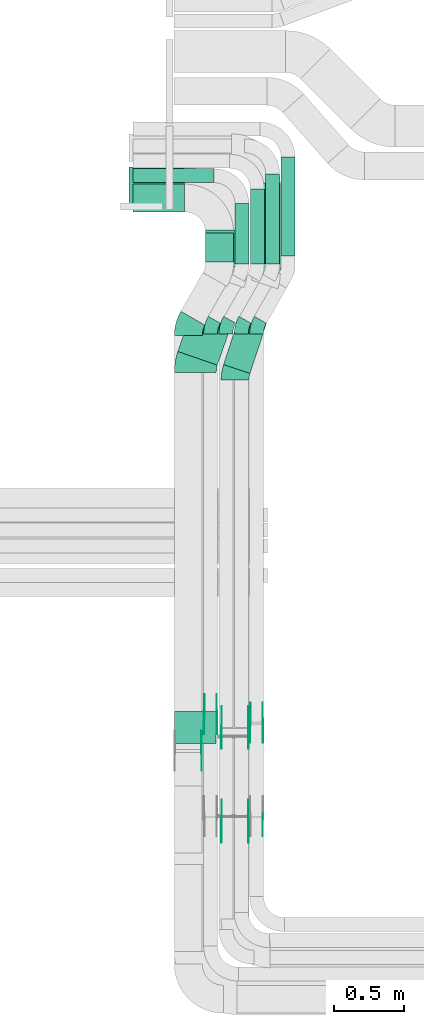
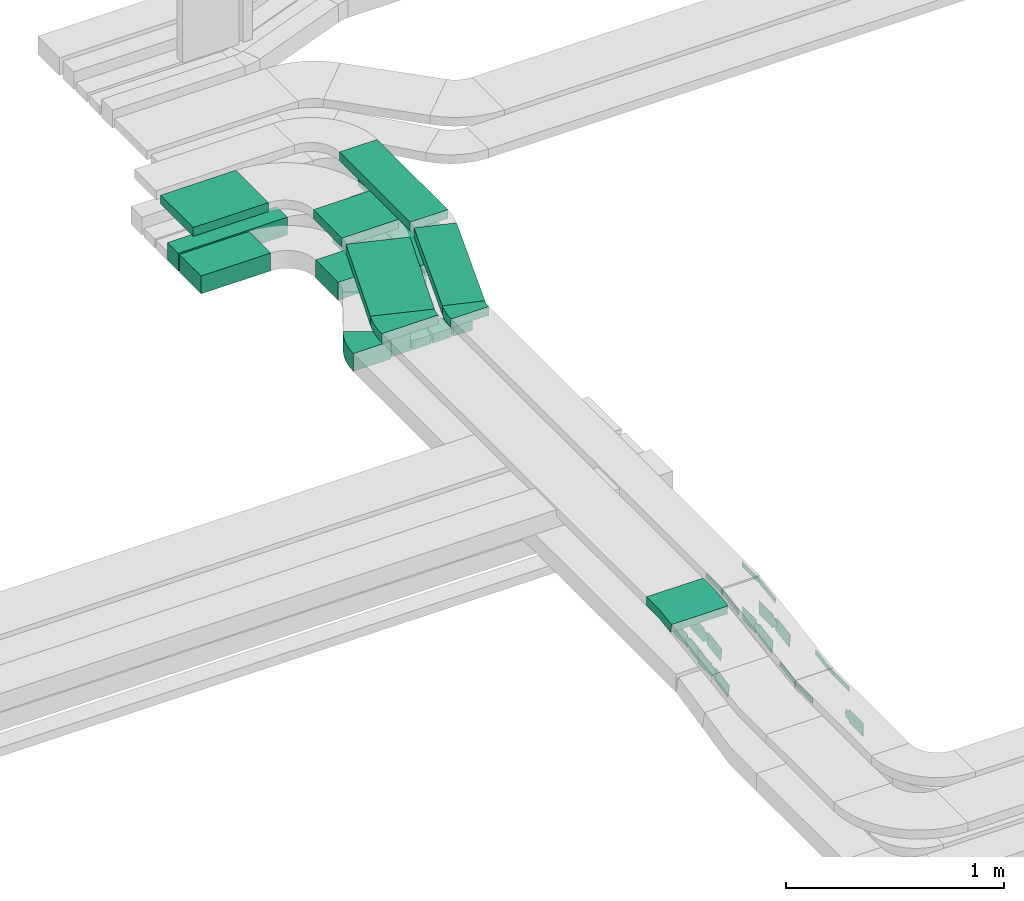
# One storey, part 5 of 28: 27 flow fittings, 12 flow segments.
"""IFC2X3 building model written with IfcOpenShell, lengths in millimetres."""

from ifc_helpers import new_model, entity, si_unit, converted_unit, derived_unit, direction, frame, frame_2d, origin, origin_2d_with_axis, place, context, subcontext, project, spatial, polyline, circle_curve, parameter, trimmed, segment, composite_curve, rectangle, outline, extrude, source, transform, mapped, material, type_object, type_shapes, element, save


model = new_model("IFC2X3")

# Units and contexts
model_context = context("Model", 3, precision=0.01, world=origin(), true_north=direction((6.12303176911189e-17, 1.0)))
body_context = subcontext(model_context, "Body", "Model", "MODEL_VIEW")
ifc_project = project(units=[si_unit("LENGTHUNIT", "METRE", prefix="MILLI"), si_unit("AREAUNIT", "SQUARE_METRE"), si_unit("VOLUMEUNIT", "CUBIC_METRE"), converted_unit("PLANEANGLEUNIT", "DEGREE", entity("IfcRatioMeasure", 0.0174532925199433), si_unit("PLANEANGLEUNIT", "RADIAN"), dimensions=[0, 0, 0, 0, 0, 0, 0]), si_unit("MASSUNIT", "GRAM", prefix="KILO"), derived_unit("MASSDENSITYUNIT", [(si_unit("MASSUNIT", "GRAM", prefix="KILO"), 1), (si_unit("LENGTHUNIT", "METRE"), -3)]), derived_unit("MOMENTOFINERTIAUNIT", [(si_unit("LENGTHUNIT", "METRE"), 4)]), si_unit("TIMEUNIT", "SECOND"), si_unit("FREQUENCYUNIT", "HERTZ"), si_unit("THERMODYNAMICTEMPERATUREUNIT", "DEGREE_CELSIUS"), derived_unit("THERMALTRANSMITTANCEUNIT", [(si_unit("MASSUNIT", "GRAM", prefix="KILO"), 1), (si_unit("THERMODYNAMICTEMPERATUREUNIT", "KELVIN"), -1), (si_unit("TIMEUNIT", "SECOND"), -3)]), derived_unit("VOLUMETRICFLOWRATEUNIT", [(si_unit("LENGTHUNIT", "METRE"), 3), (si_unit("TIMEUNIT", "SECOND"), -1)]), derived_unit("MASSFLOWRATEUNIT", [(si_unit("MASSUNIT", "GRAM", prefix="KILO"), 1), (si_unit("TIMEUNIT", "SECOND"), -1)]), derived_unit("ROTATIONALFREQUENCYUNIT", [(si_unit("TIMEUNIT", "SECOND"), -1)]), si_unit("ELECTRICCURRENTUNIT", "AMPERE"), si_unit("ELECTRICVOLTAGEUNIT", "VOLT"), si_unit("POWERUNIT", "WATT"), si_unit("FORCEUNIT", "NEWTON", prefix="KILO"), si_unit("ILLUMINANCEUNIT", "LUX"), si_unit("LUMINOUSFLUXUNIT", "LUMEN"), si_unit("LUMINOUSINTENSITYUNIT", "CANDELA"), derived_unit("USERDEFINED", [(si_unit("MASSUNIT", "GRAM", prefix="KILO"), -1), (si_unit("LENGTHUNIT", "METRE"), -2), (si_unit("TIMEUNIT", "SECOND"), 3), (si_unit("LUMINOUSFLUXUNIT", "LUMEN"), 1)]), derived_unit("LINEARVELOCITYUNIT", [(si_unit("LENGTHUNIT", "METRE"), 1), (si_unit("TIMEUNIT", "SECOND"), -1)]), si_unit("PRESSUREUNIT", "PASCAL"), derived_unit("USERDEFINED", [(si_unit("LENGTHUNIT", "METRE"), -2), (si_unit("MASSUNIT", "GRAM", prefix="KILO"), 1), (si_unit("TIMEUNIT", "SECOND"), -2)]), derived_unit("LINEARFORCEUNIT", [(si_unit("MASSUNIT", "GRAM", prefix="KILO"), 1), (si_unit("LENGTHUNIT", "METRE"), 1), (si_unit("TIMEUNIT", "SECOND"), -2), (si_unit("LENGTHUNIT", "METRE"), -1)]), derived_unit("PLANARFORCEUNIT", [(si_unit("MASSUNIT", "GRAM", prefix="KILO"), 1), (si_unit("LENGTHUNIT", "METRE"), 1), (si_unit("TIMEUNIT", "SECOND"), -2), (si_unit("LENGTHUNIT", "METRE"), -2)])], contexts=[model_context])

# Site, building, storey
site_placement = place(None, origin())
site = spatial("IfcSite", under=ifc_project, at=site_placement, CompositionType="ELEMENT")
building_placement = place(site_placement, origin())
building = spatial("IfcBuilding", under=site, at=building_placement, CompositionType="ELEMENT")
storey_placement = place(building_placement, frame((0.0, 0.0, 15900.0)))
storey = spatial("IfcBuildingStorey", under=building, at=storey_placement, CompositionType="ELEMENT", Elevation=15900.0)

# Flow segments
cable_carrier_segment_type = type_object("IfcCableCarrierSegmentType", PredefinedType="CABLETRAYSEGMENT")
flow_segment_1_placement = place(storey_placement, frame((17298.54, 13653.75, 2607.26)))
element("IfcFlowSegment", 1, at=flow_segment_1_placement, inside=storey, type_object=cable_carrier_segment_type, context=body_context, shape_type="SweptSolid", body=[
    extrude(rectangle(XDim=709.169713057409, YDim=99.9999999999989, at=origin_2d_with_axis()), frame((50.0, 354.58, 0.0), z_axis=(0.0, 0.0, 1.0), x_axis=(0.0, 1.0, 0.0)), (0.0, 0.0, 1.0), 99.9999999999989),
])
flow_segment_2_placement = place(storey_placement, frame((16968.54, 13598.0, 2607.26)))
element("IfcFlowSegment", 2, at=flow_segment_2_placement, inside=storey, type_object=cable_carrier_segment_type, context=body_context, shape_type="SweptSolid", body=[
    extrude(rectangle(XDim=431.001407067845, YDim=99.9999999999989, at=origin_2d_with_axis()), frame((50.0, 215.5, 0.0), z_axis=(0.0, 0.0, 1.0), x_axis=(0.0, 1.0, 0.0)), (0.0, 0.0, 1.0), 99.9999999999989),
])
flow_segment_3_placement = place(storey_placement, frame((17078.54, 13598.0, 2607.26)))
element("IfcFlowSegment", 3, at=flow_segment_3_placement, inside=storey, type_object=cable_carrier_segment_type, context=body_context, shape_type="SweptSolid", body=[
    extrude(rectangle(XDim=534.919754710368, YDim=99.9999999999989, at=origin_2d_with_axis()), frame((50.0, 267.46, 0.0), z_axis=(0.0, 0.0, 1.0), x_axis=(0.0, 1.0, 0.0)), (0.0, 0.0, 1.0), 50.0000000000016),
])
flow_segment_4_placement = place(storey_placement, frame((16758.54, 13611.27, 2607.26)))
element("IfcFlowSegment", 4, at=flow_segment_4_placement, inside=storey, type_object=cable_carrier_segment_type, context=body_context, shape_type="SweptSolid", body=[
    extrude(rectangle(XDim=207.731345745393, YDim=200.000000000002, at=origin_2d_with_axis()), frame((100.0, 103.87, 0.0), z_axis=(0.0, 0.0, 1.0), x_axis=(0.0, 1.0, 0.0)), (0.0, 0.0, 1.0), 99.9999999999989),
])
flow_segment_5_placement = place(storey_placement, frame((17093.54, 13530.09, 2927.26)))
element("IfcFlowSegment", 5, at=flow_segment_5_placement, inside=storey, type_object=cable_carrier_segment_type, context=body_context, shape_type="SweptSolid", body=[
    extrude(rectangle(XDim=649.073739865579, YDim=200.000000000002, at=origin_2d_with_axis()), frame((100.0, 324.54, 0.0), z_axis=(0.0, 0.0, 1.0), x_axis=(0.0, 1.0, 0.0)), (0.0, 0.0, 1.0), 50.0000000000016),
])
flow_segment_6_placement = place(storey_placement, frame((16758.54, 13575.33, 2927.26)))
element("IfcFlowSegment", 6, at=flow_segment_6_placement, inside=storey, type_object=cable_carrier_segment_type, context=body_context, shape_type="SweptSolid", body=[
    extrude(rectangle(XDim=264.198022174949, YDim=300.000000000001, at=origin_2d_with_axis()), frame((150.0, 132.1, 0.0), z_axis=(0.0, 0.0, 1.0), x_axis=(0.0, 1.0, 0.0)), (0.0, 0.0, 1.0), 50.0000000000016),
])
flow_segment_7_placement = place(storey_placement, frame((17188.54, 13598.0, 2607.26)))
element("IfcFlowSegment", 7, at=flow_segment_7_placement, inside=storey, type_object=cable_carrier_segment_type, context=body_context, shape_type="SweptSolid", body=[
    extrude(rectangle(XDim=644.919754710367, YDim=99.9999999999989, at=origin_2d_with_axis()), frame((50.0, 322.46, 0.0), z_axis=(0.0, 0.0, 1.0), x_axis=(0.0, 1.0, 0.0)), (0.0, 0.0, 1.0), 50.0000000000016),
])
flow_segment_8_placement = place(storey_placement, frame((16238.54, 13970.0, 2607.26)))
element("IfcFlowSegment", 8, at=flow_segment_8_placement, inside=storey, type_object=cable_carrier_segment_type, context=body_context, shape_type="SweptSolid", body=[
    extrude(rectangle(XDim=369.000000000007, YDim=200.000000000002, at=origin_2d_with_axis()), frame((184.5, 100.0, 0.0), z_axis=(0.0, 0.0, 1.0), x_axis=(-1.0, 0.0, 0.0)), (0.0, 0.0, 1.0), 99.9999999999989),
])
flow_segment_9_placement = place(storey_placement, frame((16238.54, 14180.0, 2607.26)))
element("IfcFlowSegment", 9, at=flow_segment_9_placement, inside=storey, type_object=cable_carrier_segment_type, context=body_context, shape_type="SweptSolid", body=[
    extrude(rectangle(XDim=579.000000000005, YDim=99.9999999999989, at=origin_2d_with_axis()), frame((289.5, 50.0, 0.0), z_axis=(0.0, 0.0, 1.0), x_axis=(-1.0, 0.0, 0.0)), (0.0, 0.0, 1.0), 99.9999999999989),
])
flow_segment_10_placement = place(storey_placement, frame((16558.44, 12871.39, 2927.26)))
element("IfcFlowSegment", 10, at=flow_segment_10_placement, inside=storey, type_object=cable_carrier_segment_type, context=body_context, shape_type="SweptSolid", body=[
    extrude(rectangle(XDim=587.335852841362, YDim=299.999999999998, at=origin_2d_with_axis()), frame((237.58, 326.53, 0.0), z_axis=(0.0, 0.0, 1.0), x_axis=(-0.326179561314503, -0.945307830169981, 0.0)), (0.0, 0.0, 1.0), 50.0000000000016),
])
flow_segment_11_placement = place(storey_placement, frame((16886.34, 12812.75, 2927.26)))
element("IfcFlowSegment", 11, at=flow_segment_11_placement, inside=storey, type_object=cable_carrier_segment_type, context=body_context, shape_type="SweptSolid", body=[
    extrude(rectangle(XDim=637.96363640816, YDim=200.000000000001, at=origin_2d_with_axis()), frame((194.68, 334.26, 0.0), z_axis=(0.0, 0.0, 1.0), x_axis=(0.312518466204231, 0.949911684464064, 0.0)), (0.0, 0.0, 1.0), 50.0000000000016),
])
flow_segment_12_placement = place(storey_placement, frame((16208.54, 13990.53, 2927.26)))
element("IfcFlowSegment", 12, at=flow_segment_12_placement, inside=storey, type_object=cable_carrier_segment_type, context=body_context, shape_type="SweptSolid", body=[
    extrude(rectangle(XDim=399.000000000007, YDim=300.000000000001, at=origin_2d_with_axis()), frame((199.5, 150.0, 0.0), z_axis=(0.0, 0.0, 1.0), x_axis=(-1.0, 0.0, 0.0)), (0.0, 0.0, 1.0), 50.0000000000038),
])

# Flow fittings
ifc_material_1 = material(Name="G")
cable_carrier_fitting_type_1 = type_object("IfcCableCarrierFittingType", PredefinedType="NOTDEFINED", material=ifc_material_1)
shared_shape_1 = source(origin(), body_context, "Body", "SweptSolid", [
    extrude(outline(composite_curve([segment(trimmed(circle_curve(frame_2d((-44.59, 0.0), x_axis=(1.0, 0.0)), 12.5), [parameter(90.0000000000007)], [parameter(270.0)], True, "PARAMETER"), True, "CONTINUOUS"), segment(polyline([(-44.59, -12.5), (-33.09, -12.5)]), True, "CONTINUOUS"), segment(polyline([(-33.09, -12.5), (-31.23, -14.5)]), True, "CONTINUOUS"), segment(polyline([(-31.23, -14.5), (108.91, -14.5)]), True, "CONTINUOUS"), segment(polyline([(108.91, -14.5), (108.91, 14.5)]), True, "CONTINUOUS"), segment(polyline([(108.91, 14.5), (-31.23, 14.5)]), True, "CONTINUOUS"), segment(polyline([(-31.23, 14.5), (-33.09, 12.5)]), True, "CONTINUOUS"), segment(polyline([(-33.09, 12.5), (-44.59, 12.5)]), True, "CONTINUOUS")], self_intersect=False)), frame((44.59, 0.0, 0.0), z_axis=(0.0, 0.0, -1.0), x_axis=(1.0, 0.0, 0.0)), (0.0, 0.0, -1.0), 2.0),
])
type_shapes(cable_carrier_fitting_type_1, [shared_shape_1])
flow_fitting_1_placement = place(storey_placement, frame((17063.96, 10273.8, 2952.26), z_axis=(1.0, 0.0, 0.0), x_axis=(0.0, -0.987576211285316, -0.157140786886606)))
element("IfcFlowFitting", 13, at=flow_fitting_1_placement, inside=storey, type_object=cable_carrier_fitting_type_1, material=ifc_material_1, context=body_context, shape_type="MappedRepresentation", body=[
    mapped(shared_shape_1, transform((0.0, 0.0, 0.0), scale=1.0)),
])
cable_carrier_fitting_type_2 = type_object("IfcCableCarrierFittingType", PredefinedType="NOTDEFINED", material=ifc_material_1)
type_shapes(cable_carrier_fitting_type_2, [shared_shape_1])
flow_fitting_2_placement = place(storey_placement, frame((16875.04, 10273.8, 2952.26), z_axis=(-1.0, 0.0, 0.0), x_axis=(0.0, 1.0, 0.0)))
element("IfcFlowFitting", 14, at=flow_fitting_2_placement, inside=storey, type_object=cable_carrier_fitting_type_2, material=ifc_material_1, context=body_context, shape_type="MappedRepresentation", body=[
    mapped(shared_shape_1, transform((0.0, 0.0, 0.0), scale=1.0)),
])
flow_fitting_3_placement = place(storey_placement, frame((16873.04, 9599.72, 2845.0), z_axis=(-1.0, 0.0, 0.0), x_axis=(0.0, -1.0, 0.0)))
element("IfcFlowFitting", 15, at=flow_fitting_3_placement, inside=storey, type_object=cable_carrier_fitting_type_1, material=ifc_material_1, context=body_context, shape_type="MappedRepresentation", body=[
    mapped(shared_shape_1, transform((0.0, 0.0, 0.0), scale=1.0)),
])
flow_fitting_4_placement = place(storey_placement, frame((17061.96, 9599.72, 2845.0), z_axis=(1.0, 0.0, 0.0), x_axis=(0.0, 0.987576211285319, 0.157140786886585)))
element("IfcFlowFitting", 16, at=flow_fitting_4_placement, inside=storey, type_object=cable_carrier_fitting_type_2, material=ifc_material_1, context=body_context, shape_type="MappedRepresentation", body=[
    mapped(shared_shape_1, transform((0.0, 0.0, 0.0), scale=1.0)),
])
cable_carrier_fitting_type_3 = type_object("IfcCableCarrierFittingType", PredefinedType="NOTDEFINED", material=ifc_material_1)
shared_shape_2 = source(origin(), body_context, "Body", "SweptSolid", [
    extrude(outline(composite_curve([segment(trimmed(circle_curve(frame_2d((-44.59, 0.0), x_axis=(1.0, 0.0)), 12.5), [parameter(90.0000000000007)], [parameter(270.0)], True, "PARAMETER"), True, "CONTINUOUS"), segment(polyline([(-44.59, -12.5), (-33.09, -12.5)]), True, "CONTINUOUS"), segment(polyline([(-33.09, -12.5), (-31.23, -14.5)]), True, "CONTINUOUS"), segment(polyline([(-31.23, -14.5), (108.91, -14.5)]), True, "CONTINUOUS"), segment(polyline([(108.91, -14.5), (108.91, 14.5)]), True, "CONTINUOUS"), segment(polyline([(108.91, 14.5), (-31.23, 14.5)]), True, "CONTINUOUS"), segment(polyline([(-31.23, 14.5), (-33.09, 12.5)]), True, "CONTINUOUS"), segment(polyline([(-33.09, 12.5), (-44.59, 12.5)]), True, "CONTINUOUS")], self_intersect=False)), frame((44.59, 0.0, 0.0)), (0.0, 0.0, 1.0), 2.0),
])
type_shapes(cable_carrier_fitting_type_3, [shared_shape_2])
flow_fitting_5_placement = place(storey_placement, frame((16873.04, 10273.8, 2952.26), z_axis=(-1.0, 0.0, 0.0), x_axis=(0.0, -0.987576211285316, -0.157140786886606)))
element("IfcFlowFitting", 17, at=flow_fitting_5_placement, inside=storey, type_object=cable_carrier_fitting_type_3, material=ifc_material_1, context=body_context, shape_type="MappedRepresentation", body=[
    mapped(shared_shape_2, transform((0.0, 0.0, 0.0), scale=1.0)),
])
cable_carrier_fitting_type_4 = type_object("IfcCableCarrierFittingType", PredefinedType="NOTDEFINED", material=ifc_material_1)
type_shapes(cable_carrier_fitting_type_4, [shared_shape_2])
flow_fitting_6_placement = place(storey_placement, frame((17061.96, 10273.8, 2952.26), z_axis=(1.0, 0.0, 0.0), x_axis=(0.0, 1.0, 0.0)))
element("IfcFlowFitting", 18, at=flow_fitting_6_placement, inside=storey, type_object=cable_carrier_fitting_type_4, material=ifc_material_1, context=body_context, shape_type="MappedRepresentation", body=[
    mapped(shared_shape_2, transform((0.0, 0.0, 0.0), scale=1.0)),
])
flow_fitting_7_placement = place(storey_placement, frame((17063.96, 9599.72, 2845.0), z_axis=(1.0, 0.0, 0.0), x_axis=(0.0, -1.0, 0.0)))
element("IfcFlowFitting", 19, at=flow_fitting_7_placement, inside=storey, type_object=cable_carrier_fitting_type_3, material=ifc_material_1, context=body_context, shape_type="MappedRepresentation", body=[
    mapped(shared_shape_2, transform((0.0, 0.0, 0.0), scale=1.0)),
])
flow_fitting_8_placement = place(storey_placement, frame((16875.04, 9599.72, 2845.0), z_axis=(-1.0, 0.0, 0.0), x_axis=(0.0, 0.987576211285319, 0.157140786886585)))
element("IfcFlowFitting", 20, at=flow_fitting_8_placement, inside=storey, type_object=cable_carrier_fitting_type_4, material=ifc_material_1, context=body_context, shape_type="MappedRepresentation", body=[
    mapped(shared_shape_2, transform((0.0, 0.0, 0.0), scale=1.0)),
])
cable_carrier_fitting_type_5 = type_object("IfcCableCarrierFittingType", PredefinedType="NOTDEFINED", material=ifc_material_1)
shared_shape_3 = source(origin(), body_context, "Body", "SweptSolid", [
    extrude(outline(composite_curve([segment(trimmed(circle_curve(frame_2d((-41.47, 0.0), x_axis=(1.0, 0.0)), 25.0), [parameter(90.0000000000007)], [parameter(270.0)], True, "PARAMETER"), True, "CONTINUOUS"), segment(polyline([(-41.47, -25.0), (-29.97, -25.0)]), True, "CONTINUOUS"), segment(polyline([(-29.97, -25.0), (-28.1, -38.5)]), True, "CONTINUOUS"), segment(polyline([(-28.1, -38.5), (99.53, -38.5)]), True, "CONTINUOUS"), segment(polyline([(99.53, -38.5), (99.53, 38.5)]), True, "CONTINUOUS"), segment(polyline([(99.53, 38.5), (-28.1, 38.5)]), True, "CONTINUOUS"), segment(polyline([(-28.1, 38.5), (-29.97, 25.0)]), True, "CONTINUOUS"), segment(polyline([(-29.97, 25.0), (-41.47, 25.0)]), True, "CONTINUOUS")], self_intersect=False)), frame((41.47, 0.0, 0.0), z_axis=(0.0, 0.0, -1.0), x_axis=(1.0, 0.0, 0.0)), (0.0, 0.0, -1.0), 2.0),
])
type_shapes(cable_carrier_fitting_type_5, [shared_shape_3])
flow_fitting_9_placement = place(storey_placement, frame((16838.96, 10369.81, 2657.26), z_axis=(1.0, 0.0, 0.0), x_axis=(0.0, -0.989493546804656, -0.144577041164712)))
element("IfcFlowFitting", 21, at=flow_fitting_9_placement, inside=storey, type_object=cable_carrier_fitting_type_5, material=ifc_material_1, context=body_context, shape_type="MappedRepresentation", body=[
    mapped(shared_shape_3, transform((0.0, 0.0, 0.0), scale=1.0)),
])
cable_carrier_fitting_type_6 = type_object("IfcCableCarrierFittingType", PredefinedType="NOTDEFINED", material=ifc_material_1)
type_shapes(cable_carrier_fitting_type_6, [shared_shape_3])
flow_fitting_10_placement = place(storey_placement, frame((16750.04, 10369.81, 2657.26), z_axis=(-1.0, 0.0, 0.0), x_axis=(0.0, 1.0, 0.0)))
element("IfcFlowFitting", 22, at=flow_fitting_10_placement, inside=storey, type_object=cable_carrier_fitting_type_6, material=ifc_material_1, context=body_context, shape_type="MappedRepresentation", body=[
    mapped(shared_shape_3, transform((0.0, 0.0, 0.0), scale=1.0)),
])
flow_fitting_11_placement = place(storey_placement, frame((17168.96, 10309.81, 2657.26), z_axis=(1.0, 0.0, 0.0), x_axis=(0.0, -0.987576211285325, -0.15714078688655)))
element("IfcFlowFitting", 23, at=flow_fitting_11_placement, inside=storey, type_object=cable_carrier_fitting_type_5, material=ifc_material_1, context=body_context, shape_type="MappedRepresentation", body=[
    mapped(shared_shape_3, transform((0.0, 0.0, 0.0), scale=1.0)),
])
flow_fitting_12_placement = place(storey_placement, frame((17080.04, 10309.81, 2657.26), z_axis=(-1.0, 0.0, 0.0), x_axis=(0.0, 1.0, 0.0)))
element("IfcFlowFitting", 24, at=flow_fitting_12_placement, inside=storey, type_object=cable_carrier_fitting_type_6, material=ifc_material_1, context=body_context, shape_type="MappedRepresentation", body=[
    mapped(shared_shape_3, transform((0.0, 0.0, 0.0), scale=1.0)),
])
flow_fitting_13_placement = place(storey_placement, frame((16728.96, 10109.81, 2657.26), z_axis=(1.0, 0.0, 0.0), x_axis=(0.0, -0.976627229070768, -0.214940120586069)))
element("IfcFlowFitting", 25, at=flow_fitting_13_placement, inside=storey, type_object=cable_carrier_fitting_type_5, material=ifc_material_1, context=body_context, shape_type="MappedRepresentation", body=[
    mapped(shared_shape_3, transform((0.0, 0.0, 0.0), scale=1.0)),
])
cable_carrier_fitting_type_7 = type_object("IfcCableCarrierFittingType", PredefinedType="NOTDEFINED", material=ifc_material_1)
shared_shape_4 = source(origin(), body_context, "Body", "SweptSolid", [
    extrude(outline(composite_curve([segment(trimmed(circle_curve(frame_2d((-41.47, 0.0), x_axis=(1.0, 0.0)), 25.0), [parameter(90.0000000000007)], [parameter(270.0)], True, "PARAMETER"), True, "CONTINUOUS"), segment(polyline([(-41.47, -25.0), (-29.97, -25.0)]), True, "CONTINUOUS"), segment(polyline([(-29.97, -25.0), (-28.1, -38.5)]), True, "CONTINUOUS"), segment(polyline([(-28.1, -38.5), (99.53, -38.5)]), True, "CONTINUOUS"), segment(polyline([(99.53, -38.5), (99.53, 38.5)]), True, "CONTINUOUS"), segment(polyline([(99.53, 38.5), (-28.1, 38.5)]), True, "CONTINUOUS"), segment(polyline([(-28.1, 38.5), (-29.97, 25.0)]), True, "CONTINUOUS"), segment(polyline([(-29.97, 25.0), (-41.47, 25.0)]), True, "CONTINUOUS")], self_intersect=False)), frame((41.47, 0.0, 0.0)), (0.0, 0.0, 1.0), 2.0),
])
type_shapes(cable_carrier_fitting_type_7, [shared_shape_4])
flow_fitting_14_placement = place(storey_placement, frame((16748.04, 10369.81, 2657.26), z_axis=(-1.0, 0.0, 0.0), x_axis=(0.0, -0.989493546804656, -0.144577041164712)))
element("IfcFlowFitting", 26, at=flow_fitting_14_placement, inside=storey, type_object=cable_carrier_fitting_type_7, material=ifc_material_1, context=body_context, shape_type="MappedRepresentation", body=[
    mapped(shared_shape_4, transform((0.0, 0.0, 0.0), scale=1.0)),
])
cable_carrier_fitting_type_8 = type_object("IfcCableCarrierFittingType", PredefinedType="NOTDEFINED", material=ifc_material_1)
type_shapes(cable_carrier_fitting_type_8, [shared_shape_4])
flow_fitting_15_placement = place(storey_placement, frame((16836.96, 10369.81, 2657.26), z_axis=(1.0, 0.0, 0.0), x_axis=(0.0, 1.0, 0.0)))
element("IfcFlowFitting", 27, at=flow_fitting_15_placement, inside=storey, type_object=cable_carrier_fitting_type_8, material=ifc_material_1, context=body_context, shape_type="MappedRepresentation", body=[
    mapped(shared_shape_4, transform((0.0, 0.0, 0.0), scale=1.0)),
])
flow_fitting_16_placement = place(storey_placement, frame((17078.04, 10309.81, 2657.26), z_axis=(-1.0, 0.0, 0.0), x_axis=(0.0, -0.987576211285325, -0.15714078688655)))
element("IfcFlowFitting", 28, at=flow_fitting_16_placement, inside=storey, type_object=cable_carrier_fitting_type_7, material=ifc_material_1, context=body_context, shape_type="MappedRepresentation", body=[
    mapped(shared_shape_4, transform((0.0, 0.0, 0.0), scale=1.0)),
])
for number, where, z_axis, x_axis in (
    (29, (17166.96, 10309.81, 2657.26), (1.0, 0.0, 0.0), (0.0, 1.0, 0.0)),
    (30, (17166.96, 9635.73, 2550.0), (1.0, 0.0, 0.0), (0.0, -1.0, 0.0)),
    (31, (16726.96, 10109.81, 2657.26), (1.0, 0.0, 0.0), (0.0, 1.0, 0.0)),
):
    element("IfcFlowFitting", number, at=place(storey_placement, frame(where, z_axis=z_axis, x_axis=x_axis)), inside=storey, type_object=cable_carrier_fitting_type_8, material=ifc_material_1, context=body_context, shape_type="MappedRepresentation", body=[
        mapped(shared_shape_4, transform((0.0, 0.0, 0.0), scale=1.0)),
    ])
ifc_material_2 = material()
cable_carrier_fitting_type_9 = type_object("IfcCableCarrierFittingType", Name="470_DKC_S5_Variable Angle Elbow 0-45:-", PredefinedType="NOTDEFINED", material=ifc_material_2)
shared_shape_5 = source(origin(), body_context, "Body", "SweptSolid", [
    extrude(outline(composite_curve([segment(polyline([(-62.95, -116.57), (-61.95, -116.57)]), True, "CONTINUOUS"), segment(trimmed(circle_curve(frame_2d((-61.95, 233.43), x_axis=(0.0, -1.0)), 350.0), [parameter(0.0)], [parameter(29.7274101248659)], True, "PARAMETER"), True, "CONTINUOUS"), segment(polyline([(111.6, -70.51), (112.47, -70.02)]), True, "CONTINUOUS"), segment(polyline([(112.47, -70.02), (13.3, 103.66)]), True, "CONTINUOUS"), segment(polyline([(13.3, 103.66), (12.43, 103.17)]), True, "CONTINUOUS"), segment(trimmed(circle_curve(frame_2d((-61.95, 233.43), x_axis=(0.0, -1.0)), 150.0), [parameter(0.0)], [parameter(29.7274101248659)], True, "PARAMETER"), False, "CONTINUOUS"), segment(polyline([(-61.95, 83.43), (-62.95, 83.43)]), True, "CONTINUOUS"), segment(polyline([(-62.95, 83.43), (-62.95, -116.57)]), True, "CONTINUOUS")], self_intersect=False)), frame((-4.4, 16.57, -50.0)), (0.0, 0.0, 1.0), 100.0),
])
type_shapes(cable_carrier_fitting_type_9, [shared_shape_5])
flow_fitting_17_placement = place(storey_placement, frame((16633.5, 13149.81, 2657.26), z_axis=(0.0, 0.0, 1.0), x_axis=(-0.495874162367818, -0.868394389143559, 0.0)))
element("IfcFlowFitting", 32, at=flow_fitting_17_placement, inside=storey, type_object=cable_carrier_fitting_type_9, material=ifc_material_2, Name="470_DKC_S5_Variable Angle Elbow 0-45:-", ObjectType="470_DKC_S5_Variable Angle Elbow 0-45:-", context=body_context, shape_type="MappedRepresentation", body=[
    mapped(shared_shape_5, transform((0.0, 0.0, 0.0), scale=1.0)),
])
cable_carrier_fitting_type_10 = type_object("IfcCableCarrierFittingType", Name="470_DKC_S5_Variable Angle Elbow 0-45:-", PredefinedType="NOTDEFINED", material=ifc_material_2)
shared_shape_6 = source(origin(), body_context, "Body", "SweptSolid", [
    extrude(outline(composite_curve([segment(polyline([(-50.55, -63.28), (-49.55, -63.28)]), True, "CONTINUOUS"), segment(trimmed(circle_curve(frame_2d((-49.55, 186.72), x_axis=(0.0, -1.0)), 250.0), [parameter(0.0)], [parameter(29.7274101248686)], True, "PARAMETER"), True, "CONTINUOUS"), segment(polyline([(74.41, -30.38), (75.28, -29.89)]), True, "CONTINUOUS"), segment(polyline([(75.28, -29.89), (25.7, 56.95)]), True, "CONTINUOUS"), segment(polyline([(25.7, 56.95), (24.83, 56.46)]), True, "CONTINUOUS"), segment(trimmed(circle_curve(frame_2d((-49.55, 186.72), x_axis=(0.0, -1.0)), 150.0), [parameter(0.0)], [parameter(29.7274101248686)], True, "PARAMETER"), False, "CONTINUOUS"), segment(polyline([(-49.55, 36.72), (-50.55, 36.72)]), True, "CONTINUOUS"), segment(polyline([(-50.55, 36.72), (-50.55, -63.28)]), True, "CONTINUOUS")], self_intersect=False)), frame((-3.53, 13.28, -50.0)), (0.0, 0.0, 1.0), 100.0),
])
type_shapes(cable_carrier_fitting_type_10, [shared_shape_6])
for number, where, z_axis, x_axis, name in (
    (33, (17123.5, 13149.81, 2657.26), (0.0, 0.0, 1.0), (-0.495874162367859, -0.868394389143536, 0.0), "470_DKC_S5_Variable Angle Elbow 0-45:-"),
    (34, (16793.5, 13149.81, 2657.26), (0.0, 0.0, 1.0), (-0.495874162367857, -0.868394389143537, 0.0), "470_DKC_S5_Variable Angle Elbow 0-45:-"),
):
    element("IfcFlowFitting", number, at=place(storey_placement, frame(where, z_axis=z_axis, x_axis=x_axis)), inside=storey, type_object=cable_carrier_fitting_type_10, material=ifc_material_2, Name=name, ObjectType="470_DKC_S5_Variable Angle Elbow 0-45:-", context=body_context, shape_type="MappedRepresentation", body=[
        mapped(shared_shape_6, transform((0.0, 0.0, 0.0), scale=1.0)),
    ])
cable_carrier_fitting_type_11 = type_object("IfcCableCarrierFittingType", Name="470_DKC_S5_Variable Angle Elbow 0-45:-", PredefinedType="NOTDEFINED", material=ifc_material_2)
shared_shape_7 = source(origin(), body_context, "Body", "SweptSolid", [
    extrude(outline(composite_curve([segment(polyline([(-50.55, -63.28), (-49.55, -63.28)]), True, "CONTINUOUS"), segment(trimmed(circle_curve(frame_2d((-49.55, 186.72), x_axis=(0.0, -1.0)), 250.0), [parameter(0.0)], [parameter(29.7274101248684)], True, "PARAMETER"), True, "CONTINUOUS"), segment(polyline([(74.41, -30.38), (75.28, -29.89)]), True, "CONTINUOUS"), segment(polyline([(75.28, -29.89), (25.7, 56.95)]), True, "CONTINUOUS"), segment(polyline([(25.7, 56.95), (24.83, 56.46)]), True, "CONTINUOUS"), segment(trimmed(circle_curve(frame_2d((-49.55, 186.72), x_axis=(0.0, -1.0)), 150.0), [parameter(0.0)], [parameter(29.7274101248684)], True, "PARAMETER"), False, "CONTINUOUS"), segment(polyline([(-49.55, 36.72), (-50.55, 36.72)]), True, "CONTINUOUS"), segment(polyline([(-50.55, 36.72), (-50.55, -63.28)]), True, "CONTINUOUS")], self_intersect=False)), frame((-3.53, 13.28, -25.0)), (0.0, 0.0, 1.0), 50.0),
])
type_shapes(cable_carrier_fitting_type_11, [shared_shape_7])
for number, where, z_axis, x_axis, name in (
    (35, (16903.5, 13149.81, 2632.26), (0.0, 0.0, 1.0), (-0.495874162367856, -0.868394389143537, 0.0), "470_DKC_S5_Variable Angle Elbow 0-45:-"),
    (36, (17013.5, 13149.81, 2632.26), (0.0, 0.0, 1.0), (-0.495874162367856, -0.868394389143537, 0.0), "470_DKC_S5_Variable Angle Elbow 0-45:-"),
):
    element("IfcFlowFitting", number, at=place(storey_placement, frame(where, z_axis=z_axis, x_axis=x_axis)), inside=storey, type_object=cable_carrier_fitting_type_11, material=ifc_material_2, Name=name, ObjectType="470_DKC_S5_Variable Angle Elbow 0-45:-", context=body_context, shape_type="MappedRepresentation", body=[
        mapped(shared_shape_7, transform((0.0, 0.0, 0.0), scale=1.0)),
    ])
cable_carrier_fitting_type_12 = type_object("IfcCableCarrierFittingType", Name="470_DKC_S5_Variable Angle Elbow 0-45:-", PredefinedType="NOTDEFINED", material=ifc_material_2)
shared_shape_8 = source(origin(), body_context, "Body", "SweptSolid", [
    extrude(outline(composite_curve([segment(polyline([(-49.91, -158.29), (-48.91, -158.29)]), True, "CONTINUOUS"), segment(trimmed(circle_curve(frame_2d((-48.91, 291.71), x_axis=(0.0, -1.0)), 450.0), [parameter(0.0)], [parameter(19.0370536725762)], True, "PARAMETER"), True, "CONTINUOUS"), segment(polyline([(97.87, -133.67), (98.81, -133.35)]), True, "CONTINUOUS"), segment(polyline([(98.81, -133.35), (0.96, 150.24)]), True, "CONTINUOUS"), segment(polyline([(0.96, 150.24), (0.01, 149.92)]), True, "CONTINUOUS"), segment(trimmed(circle_curve(frame_2d((-48.91, 291.71), x_axis=(0.0, -1.0)), 150.0), [parameter(0.0)], [parameter(19.0370536725762)], True, "PARAMETER"), False, "CONTINUOUS"), segment(polyline([(-48.91, 141.71), (-49.91, 141.71)]), True, "CONTINUOUS"), segment(polyline([(-49.91, 141.71), (-49.91, -158.29)]), True, "CONTINUOUS")], self_intersect=False)), frame((-1.39, 8.29, -25.0)), (0.0, 0.0, 1.0), 49.9999999999993),
])
type_shapes(cable_carrier_fitting_type_12, [shared_shape_8])
flow_fitting_18_placement = place(storey_placement, frame((16683.5, 12871.82, 2952.26), z_axis=(0.0, 0.0, 1.0), x_axis=(-0.326179561314503, -0.945307830169981, 0.0)))
element("IfcFlowFitting", 37, at=flow_fitting_18_placement, inside=storey, type_object=cable_carrier_fitting_type_12, material=ifc_material_2, Name="470_DKC_S5_Variable Angle Elbow 0-45:-", ObjectType="470_DKC_S5_Variable Angle Elbow 0-45:-", context=body_context, shape_type="MappedRepresentation", body=[
    mapped(shared_shape_8, transform((0.0, 0.0, 0.0), scale=1.0)),
])
cable_carrier_fitting_type_13 = type_object("IfcCableCarrierFittingType", Name="470_DKC_S5_Variable Angle Elbow 0-45:-", PredefinedType="NOTDEFINED", material=ifc_material_2)
shared_shape_9 = source(origin(), body_context, "Body", "SweptSolid", [
    extrude(outline(composite_curve([segment(polyline([(-40.05, -106.34), (-39.05, -106.34)]), True, "CONTINUOUS"), segment(trimmed(circle_curve(frame_2d((-39.05, 243.66), x_axis=(0.0, -1.0)), 350.0), [parameter(0.0)], [parameter(18.2110706859138)], True, "PARAMETER"), True, "CONTINUOUS"), segment(polyline([(70.33, -88.81), (71.28, -88.5)]), True, "CONTINUOUS"), segment(polyline([(71.28, -88.5), (8.78, 101.49)]), True, "CONTINUOUS"), segment(polyline([(8.78, 101.49), (7.83, 101.17)]), True, "CONTINUOUS"), segment(trimmed(circle_curve(frame_2d((-39.05, 243.66), x_axis=(0.0, -1.0)), 150.0), [parameter(0.0)], [parameter(18.2110706859138)], True, "PARAMETER"), False, "CONTINUOUS"), segment(polyline([(-39.05, 93.66), (-40.05, 93.66)]), True, "CONTINUOUS"), segment(polyline([(-40.05, 93.66), (-40.05, -106.34)]), True, "CONTINUOUS")], self_intersect=False)), frame((-1.02, 6.34, -25.0)), (0.0, 0.0, 1.0), 50.0000000000005),
])
type_shapes(cable_carrier_fitting_type_13, [shared_shape_9])
flow_fitting_19_placement = place(storey_placement, frame((16968.5, 12804.99, 2952.26), z_axis=(0.0, 0.0, 1.0), x_axis=(-0.31251846620422, -0.949911684464067, 0.0)))
element("IfcFlowFitting", 38, at=flow_fitting_19_placement, inside=storey, type_object=cable_carrier_fitting_type_13, material=ifc_material_2, Name="470_DKC_S5_Variable Angle Elbow 0-45:-", ObjectType="470_DKC_S5_Variable Angle Elbow 0-45:-", context=body_context, shape_type="MappedRepresentation", body=[
    mapped(shared_shape_9, transform((0.0, 0.0, 0.0), scale=1.0)),
])
cable_carrier_fitting_type_14 = type_object("IfcCableCarrierFittingType", Name="470_DKC_S5_CD 90 external vertical angle:-", PredefinedType="NOTDEFINED", material=ifc_material_2)
shared_shape_10 = source(origin(), body_context, "Body", "SweptSolid", [
    extrude(outline(composite_curve([segment(polyline([(-113.46, -29.55), (-11.66, -29.55)]), True, "CONTINUOUS"), segment(trimmed(circle_curve(frame_2d((-11.66, 160.45), x_axis=(0.0, -1.0)), 189.999999999999), [parameter(0.0)], [parameter(8.31278735285435)], True, "PARAMETER"), True, "CONTINUOUS"), segment(polyline([(15.81, -27.55), (116.54, -12.83)]), True, "CONTINUOUS"), segment(polyline([(116.54, -12.83), (109.31, 36.64)]), True, "CONTINUOUS"), segment(polyline([(109.31, 36.64), (8.58, 21.92)]), True, "CONTINUOUS"), segment(trimmed(circle_curve(frame_2d((-11.66, 160.45), x_axis=(0.0, -1.0)), 139.999999999999), [parameter(0.0)], [parameter(8.31278735285435)], True, "PARAMETER"), False, "CONTINUOUS"), segment(polyline([(-11.66, 20.45), (-113.46, 20.45)]), True, "CONTINUOUS"), segment(polyline([(-113.46, 20.45), (-113.46, -29.55)]), True, "CONTINUOUS")], self_intersect=False)), frame((-0.33, 4.55, -150.0)), (0.0, 0.0, 1.0), 300.0),
])
type_shapes(cable_carrier_fitting_type_14, [shared_shape_10])
flow_fitting_20_placement = place(storey_placement, frame((16683.5, 10273.8, 2952.26), z_axis=(1.0, 0.0, 0.0), x_axis=(0.0, -1.0, 0.0)))
element("IfcFlowFitting", 39, at=flow_fitting_20_placement, inside=storey, type_object=cable_carrier_fitting_type_14, material=ifc_material_2, Name="470_DKC_S5_CD 90 external vertical angle:-", ObjectType="470_DKC_S5_CD 90 external vertical angle:-", context=body_context, shape_type="MappedRepresentation", body=[
    mapped(shared_shape_10, transform((0.0, 0.0, 0.0), scale=1.0)),
])

save(model, "model.ifc")
